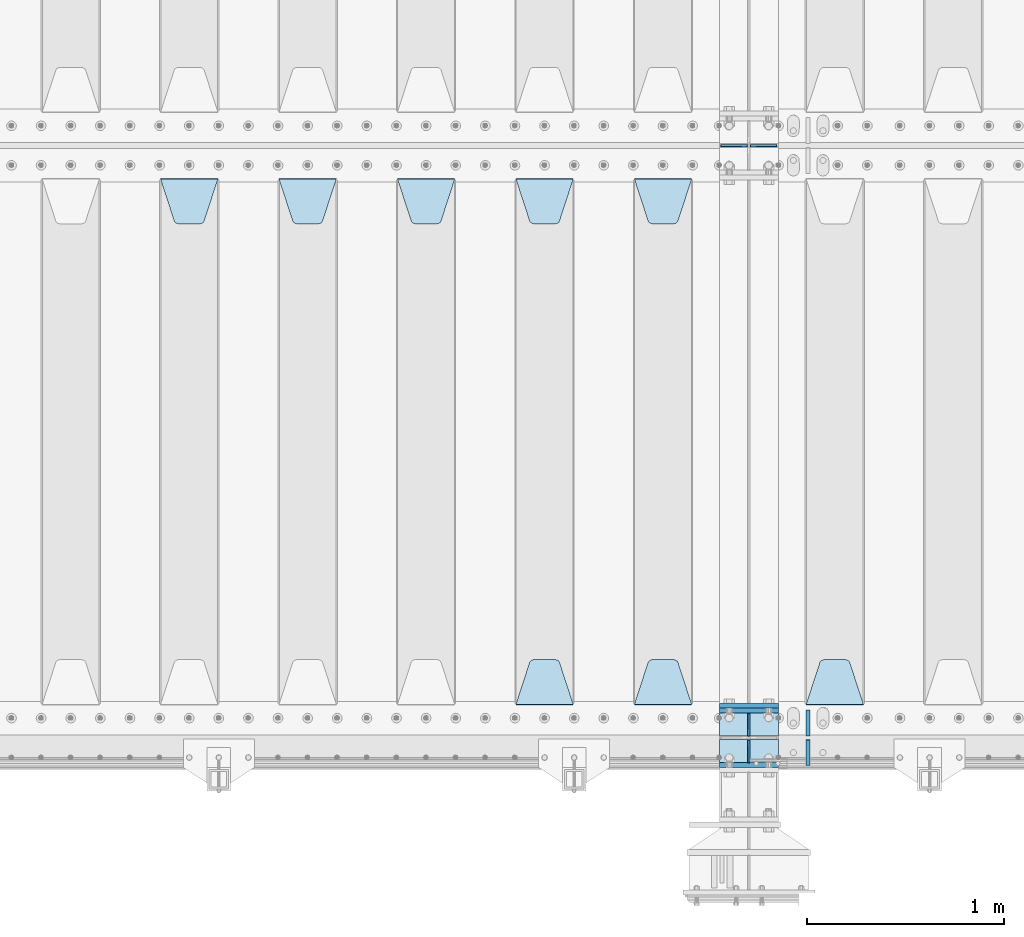
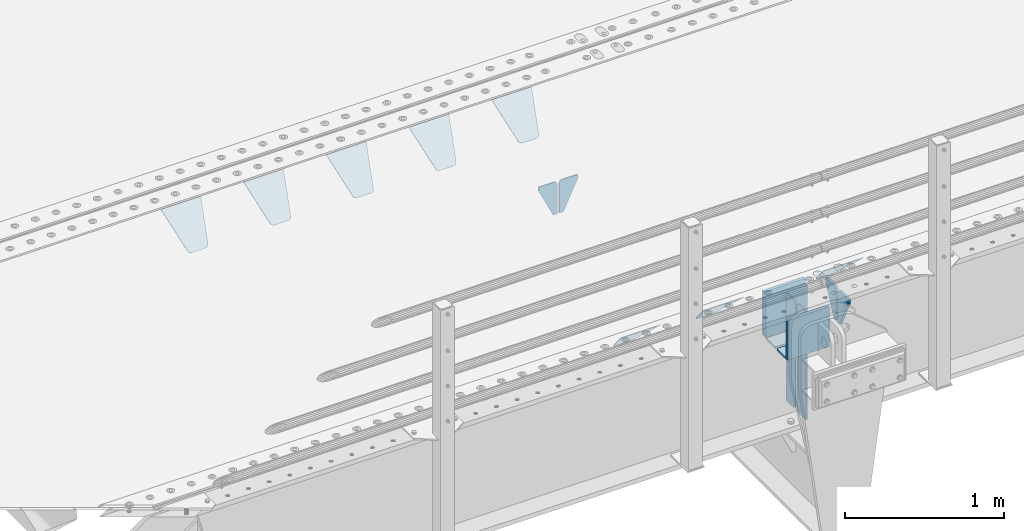
# One storey, part 224 of 270: 21 plates.
"""IFC2X3 building model written with IfcOpenShell, lengths in millimetres."""

import ifcopenshell
import ifcopenshell.guid

model = None  # the IFC model being written
_history = None  # IfcOwnerHistory: only IFC2X3 demands one
_inside = {}  # id of a spatial element -> (the spatial element, [elements in it])
_under = {}  # id of a project, library or spatial element -> (it, [spatial elements below it])
_declared = {}  # id of a project -> (the project, [libraries it declares])
_typed = {}  # id of a type object -> (the type object, [elements of that type])
_made_of = {}  # id of a material, layer set ... -> (it, [elements and type objects made of it])


def new_model(schema):
    """Start an empty IFC model of exactly this schema.

    Asked for "IFC4X3", IfcOpenShell would pick the latest addendum, in which some entities
    have other attributes; the version numbers below select the first issue.
    IFC2X3 requires an IfcOwnerHistory on every rooted entity: one is made here for all.
    """
    global model, _history
    if schema == "IFC4X3":
        model = ifcopenshell.file(schema_version=(4, 3, 0, 0))
    else:
        model = ifcopenshell.file(schema=schema)
    _inside.clear()
    _under.clear()
    _declared.clear()
    _typed.clear()
    _made_of.clear()
    _history = None
    if model.schema == "IFC2X3":
        org = make("IfcOrganization", Name="unknown")
        user = make(
            "IfcPersonAndOrganization",
            ThePerson=make("IfcPerson", FamilyName="unknown"),
            TheOrganization=org,
        )
        app = make(
            "IfcApplication",
            ApplicationDeveloper=org,
            Version="unknown",
            ApplicationFullName="unknown",
            ApplicationIdentifier="unknown",
        )
        _history = make(
            "IfcOwnerHistory",
            OwningUser=user,
            OwningApplication=app,
            ChangeAction="ADDED",
            CreationDate=0,
        )
    return model


def make(cls, **values):
    """One entity of the class cls with the attributes given. An attribute that is None is left unset."""
    return model.create_entity(
        cls, **{name: value for name, value in values.items() if value is not None}
    )


def rooted(cls, **values):
    """An entity with a GlobalId (a new one), such as an element, a storey or a relation."""
    return make(cls, GlobalId=ifcopenshell.guid.new(), OwnerHistory=_history, **values)


def si_unit(unit_type, name, prefix=None):
    """IfcSIUnit, for example si_unit("LENGTHUNIT", "METRE", prefix="MILLI")."""
    return make("IfcSIUnit", UnitType=unit_type, Prefix=prefix, Name=name)


def assignment(units):
    """IfcUnitAssignment: the units of a project."""
    return None if units is None else make("IfcUnitAssignment", Units=units)


def point(xyz):
    """IfcCartesianPoint."""
    return None if xyz is None else make("IfcCartesianPoint", Coordinates=xyz)


def direction(xyz):
    """IfcDirection."""
    return None if xyz is None else make("IfcDirection", DirectionRatios=xyz)


def frame(location, z_axis=None, x_axis=None):
    """IfcAxis2Placement3D, a coordinate frame: its origin and axes. An axis left out is left unset."""
    return make(
        "IfcAxis2Placement3D",
        Location=point(location),
        Axis=direction(z_axis),
        RefDirection=direction(x_axis),
    )


def origin_with_axes():
    """The frame at (0, 0, 0) with the z axis (0, 0, 1) and the x axis (1, 0, 0) written out."""
    return frame((0.0, 0.0, 0.0), z_axis=(0.0, 0.0, 1.0), x_axis=(1.0, 0.0, 0.0))


def place(relative_to, where):
    """IfcLocalPlacement: puts the frame where relative to a parent placement (None: the world)."""
    return make(
        "IfcLocalPlacement", PlacementRelTo=relative_to, RelativePlacement=where
    )


def context(
    kind, dimensions, precision=None, world=None, true_north=None, identifier=None
):
    """IfcGeometricRepresentationContext, for example the 3D "Model" context."""
    return make(
        "IfcGeometricRepresentationContext",
        ContextIdentifier=identifier,
        ContextType=kind,
        CoordinateSpaceDimension=dimensions,
        Precision=precision,
        WorldCoordinateSystem=world,
        TrueNorth=true_north,
    )


def subcontext(parent, identifier, kind, view, scale=None):
    """IfcGeometricRepresentationSubContext, for example "Body" below "Model"."""
    return make(
        "IfcGeometricRepresentationSubContext",
        ContextIdentifier=identifier,
        ContextType=kind,
        ParentContext=parent,
        TargetScale=scale,
        TargetView=view,
    )


def project(units=None, contexts=None):
    """IfcProject with its units and contexts."""
    return rooted(
        "IfcProject",
        Name="project",
        RepresentationContexts=contexts,
        UnitsInContext=assignment(units),
    )


def spatial(cls, under=None, at=None, **own):
    """A site, building, storey or space (cls), placed at a placement, below another one or the project."""
    s = rooted(cls, ObjectPlacement=at, **own)
    if under is not None:
        _under.setdefault(under.id(), (under, []))[1].append(s)
    return s


def faces_of(points, faces, orient=None, outer=None):
    """IfcFace entities. A face is a list of loops; a loop is a list of indices into points, from 0.

    orient and outer hold one flag for each loop. By default every Orientation is true, the
    first loop of a face is its IfcFaceOuterBound and the others are IfcFaceBound.
    """
    made = []
    for i, loops in enumerate(faces):
        bounds = []
        for j, loop in enumerate(loops):
            is_outer = j == 0 if outer is None else outer[i][j]
            bounds.append(
                make(
                    "IfcFaceOuterBound" if is_outer else "IfcFaceBound",
                    Bound=make("IfcPolyLoop", Polygon=[points[k] for k in loop]),
                    Orientation=True if orient is None else orient[i][j],
                )
            )
        made.append(make("IfcFace", Bounds=bounds))
    return made


def faceted_brep(points, faces, orient=None, outer=None, voids=None):
    """IfcFacetedBrep: a solid bounded by flat faces; with voids (closed shells), ...WithVoids."""
    shared = [point(p) for p in points]
    hull = make("IfcClosedShell", CfsFaces=faces_of(shared, faces, orient, outer))
    if voids is None:
        return make("IfcFacetedBrep", Outer=hull)
    return make(
        "IfcFacetedBrepWithVoids",
        Outer=hull,
        Voids=[
            make(cls, CfsFaces=faces_of(shared, fs, o, b)) for cls, fs, o, b in voids
        ],
    )


def shape(context_of_items, identifier, shape_type, items):
    """IfcShapeRepresentation: the items that make up one representation, for example the "Body"."""
    return make(
        "IfcShapeRepresentation",
        ContextOfItems=context_of_items,
        RepresentationIdentifier=identifier,
        RepresentationType=shape_type,
        Items=items,
    )


def material(Name=None, Category=None):
    """IfcMaterial."""
    return make("IfcMaterial", Name=Name, Category=Category)


def made_of(thing, what):
    """Note that an element or type object is made of a material, layer set ...; save() writes the relation."""
    if what is not None:
        _made_of.setdefault(what.id(), (what, []))[1].append(thing)
    return thing


def type_object(cls, material=None, **own):
    """A type object (cls), such as IfcWallType, which elements share."""
    return made_of(rooted(cls, **own), material)


def element(
    cls,
    number,
    at=None,
    inside=None,
    cuts=None,
    type_object=None,
    material=None,
    context=None,
    identifier="Body",
    shape_type=None,
    held_by="IfcProductDefinitionShape",
    body=None,
    shapes=None,
    **own,
):
    """One element of the class cls, such as IfcWall. Its Tag is "e" and its number.

    at: its placement. inside: the storey or other place that contains it. cuts: it is an
    opening in that element (IfcRelVoidsElement). A single representation is given by context,
    identifier, shape_type and body (its items); several are given by shapes. held_by: the class
    of the entity that holds the representations. save() writes the other relations.
    """
    e = rooted(cls, Tag="e%d" % number, ObjectPlacement=at, **own)
    if body is not None:
        shapes = [shape(context, identifier, shape_type, body)]
    if shapes is not None:
        e.Representation = make(held_by, Representations=shapes)
    if inside is not None:
        _inside.setdefault(inside.id(), (inside, []))[1].append(e)
    if cuts is not None:
        rooted(
            "IfcRelVoidsElement", RelatingBuildingElement=cuts, RelatedOpeningElement=e
        )
    if type_object is not None:
        _typed.setdefault(type_object.id(), (type_object, []))[1].append(e)
    return made_of(e, material)


def aggregate(whole, parts):
    """IfcRelAggregates: a whole, such as a stair, and the parts it consists of."""
    return rooted("IfcRelAggregates", RelatingObject=whole, RelatedObjects=parts)


def save(model, path):
    """Write the relations noted so far, then the file.

    IfcRelAggregates (storeys below a building ...), IfcRelContainedInSpatialStructure (elements
    in a storey), IfcRelDefinesByType, IfcRelAssociatesMaterial and IfcRelDeclares: one each for
    every whole, place, type object, material and project.
    """
    for whole, parts in _under.values():
        aggregate(whole, parts)
    for where, things in _inside.values():
        rooted(
            "IfcRelContainedInSpatialStructure",
            RelatedElements=things,
            RelatingStructure=where,
        )
    for kind, things in _typed.values():
        rooted("IfcRelDefinesByType", RelatedObjects=things, RelatingType=kind)
    for what, things in _made_of.values():
        rooted("IfcRelAssociatesMaterial", RelatedObjects=things, RelatingMaterial=what)
    for by, libraries in _declared.values():
        rooted("IfcRelDeclares", RelatingContext=by, RelatedDefinitions=libraries)
    model.write(path)


model = new_model("IFC2X3")

# Units and contexts
model_context = context("Model", 3, precision=1e-05, world=origin_with_axes())
body_context = subcontext(model_context, "Body", "Model", "MODEL_VIEW")
ifc_project = project(units=[si_unit("LENGTHUNIT", "METRE", prefix="MILLI"), si_unit("AREAUNIT", "SQUARE_METRE"), si_unit("VOLUMEUNIT", "CUBIC_METRE"), si_unit("MASSUNIT", "GRAM", prefix="KILO"), si_unit("TIMEUNIT", "SECOND"), si_unit("PLANEANGLEUNIT", "RADIAN"), si_unit("SOLIDANGLEUNIT", "STERADIAN"), si_unit("THERMODYNAMICTEMPERATUREUNIT", "DEGREE_CELSIUS"), si_unit("LUMINOUSINTENSITYUNIT", "LUMEN")], contexts=[model_context])

# Site, building, storey
site_placement = place(None, origin_with_axes())
site = spatial("IfcSite", under=ifc_project, at=site_placement, CompositionType="ELEMENT")
building_placement = place(site_placement, origin_with_axes())
building = spatial("IfcBuilding", under=site, at=building_placement, Name="Standard", CompositionType="ELEMENT")
storey_placement = place(building_placement, origin_with_axes())
storey = spatial("IfcBuildingStorey", under=building, at=storey_placement, Name="Undefined", CompositionType="ELEMENT", Elevation=0.0)

# Plates
ifc_material = material(Name="STEEL/S355N")
plate_type_1 = type_object("IfcPlateType", PredefinedType="NOTDEFINED")
plate_1_placement = place(storey_placement, frame((13885.0, -23837.5, -340.000000000044), z_axis=(0.0, 0.0, 1.0), x_axis=(1.0, 0.0, 0.0)))
element("IfcPlate", 1, at=plate_1_placement, inside=storey, type_object=plate_type_1, material=ifc_material, context=body_context, shape_type="Brep", body=[
    faceted_brep([(0.0, -12.5, 0.0), (9.27684595808387e-10, -12.5, 340.0), (9.27684595808387e-10, 12.5, 340.0), (0.0, 12.5, 0.0), (300.0, -12.5, 340.0), (300.0, 12.5, 340.0), (300.0, -12.5, 0.0), (300.0, 12.5, 0.0)], [[[0, 1, 2, 3]], [[1, 4, 5, 2]], [[4, 6, 7, 5]], [[6, 0, 3, 7]], [[5, 7, 3, 2]], [[6, 4, 1, 0]]]),
])
for number, where, z_axis, x_axis in (
    (2, (13885.0, -23862.5, -340.0), (0.0, 0.0, 1.0), (1.0, 0.0, 0.0)),
    (3, (13885.0, -24137.5, -340.0), (0.0, 0.0, 1.0), (1.0, 0.0, 0.0)),
):
    element("IfcPlate", number, at=place(storey_placement, frame(where, z_axis=z_axis, x_axis=x_axis)), inside=storey, type_object=plate_type_1, material=ifc_material, context=body_context, shape_type="Brep", body=[
        faceted_brep([(0.0, -12.5, 0.0), (0.0, -12.5, 305.0), (0.0, 12.5, 305.0), (0.0, 12.5, 0.0), (300.0, -12.5, 305.0), (300.0, 12.5, 305.0), (300.0, -12.5, 0.0), (300.0, 12.5, 0.0)], [[[0, 1, 2, 3]], [[1, 4, 5, 2]], [[4, 6, 7, 5]], [[6, 0, 3, 7]], [[5, 7, 3, 2]], [[6, 4, 1, 0]]]),
    ])
plate_type_2 = type_object("IfcPlateType", PredefinedType="NOTDEFINED")
for number, where, z_axis, x_axis in (
    (4, (13885.0, -24009.25, -343.0), (0.0, -1.0, 0.0), (1.0, 0.0, 0.0)),
    (5, (13885.0, -23990.75, -343.0), (0.0, 1.0, 0.0), (1.0, 0.0, 0.0)),
):
    element("IfcPlate", number, at=place(storey_placement, frame(where, z_axis=z_axis, x_axis=x_axis)), inside=storey, type_object=plate_type_2, material=ifc_material, context=body_context, shape_type="Brep", body=[
        faceted_brep([(0.0, -7.0, 0.0), (0.0, -7.0, 115.75), (0.0, 7.0, 115.75), (0.0, 7.0, 0.0), (300.0, -7.0, 115.75), (300.0, 7.0, 115.75), (300.0, -7.0, 0.0), (300.0, 7.0, 0.0)], [[[0, 1, 2, 3]], [[1, 4, 5, 2]], [[4, 6, 7, 5]], [[6, 0, 3, 7]], [[5, 7, 3, 2]], [[6, 4, 1, 0]]]),
    ])
plate_type_3 = type_object("IfcPlateType", PredefinedType="NOTDEFINED")
plate_2_placement = place(storey_placement, frame((14035.0, -23990.75, -35.0), z_axis=(0.0, 0.0, -1.0), x_axis=(0.0, 1.0, 0.0)))
element("IfcPlate", 6, at=plate_2_placement, inside=storey, type_object=plate_type_3, material=ifc_material, context=body_context, shape_type="Brep", body=[
    faceted_brep([(0.0, -5.0, 30.0), (0.0, -5.0, 301.0), (0.0, 5.0, 301.0), (0.0, 5.0, 30.0), (115.75, -5.0, 301.0), (115.75, 5.0, 301.0), (115.75, -5.0, 0.0), (115.75, 5.0, 0.0), (30.0, -5.0, 0.0), (30.0, 5.0, 0.0), (24.7905546699913, -5.0, 0.455767409633758), (24.7905546699913, 5.0, 0.455767409633758), (19.7393957002314, -5.0, 1.80922137642275), (19.7393957002314, 5.0, 1.80922137642275), (15.0, -5.0, 4.01923788646684), (15.0, 5.0, 4.01923788646684), (10.7163717094045, -5.0, 7.01866670643066), (10.7163717094045, 5.0, 7.01866670643066), (7.01866670642994, -5.0, 10.7163717094038), (7.01866670642994, 5.0, 10.7163717094038), (4.01923788646673, -5.0, 15.0), (4.01923788646673, 5.0, 15.0), (1.80922137642119, -5.0, 19.7393957002299), (1.80922137642119, 5.0, 19.7393957002299), (0.455767409632244, -5.0, 24.7905546699921), (0.455767409632244, 5.0, 24.7905546699921)], [[[0, 1, 2, 3]], [[1, 4, 5, 2]], [[4, 6, 7, 5]], [[6, 8, 9, 7]], [[8, 10, 11, 9]], [[10, 12, 13, 11]], [[12, 14, 15, 13]], [[14, 16, 17, 15]], [[16, 18, 19, 17]], [[18, 20, 21, 19]], [[20, 22, 23, 21]], [[22, 24, 25, 23]], [[24, 0, 3, 25]], [[5, 7, 9, 11, 13, 15, 17, 19, 21, 23, 25, 3, 2]], [[24, 22, 20, 18, 16, 14, 12, 10, 8, 6, 4, 1, 0]]]),
])
plate_3_placement = place(storey_placement, frame((14035.0, -23990.75, -350.0), z_axis=(0.0, 0.0, -1.0), x_axis=(0.0, 1.0, 0.0)))
element("IfcPlate", 7, at=plate_3_placement, inside=storey, type_object=plate_type_3, material=ifc_material, context=body_context, shape_type="Brep", body=[
    faceted_brep([(0.0, -5.0, 0.0), (0.0, -5.0, 485.0), (0.0, 5.0, 485.0), (0.0, 5.0, 0.0), (0.455767409634063, -5.0, 490.209445330008), (0.455767409634063, 5.0, 490.209445330008), (1.80922137642301, -5.0, 495.26060429977), (1.80922137642301, 5.0, 495.26060429977), (4.01923788646673, -5.0, 500.0), (4.01923788646673, 5.0, 500.0), (7.01866670642994, -5.0, 504.283628290596), (7.01866670642994, 5.0, 504.283628290596), (10.7163717094045, -5.0, 507.981333293569), (10.7163717094045, 5.0, 507.981333293569), (15.0, -5.0, 510.980762113533), (15.0, 5.0, 510.980762113533), (19.7393957002296, -5.0, 513.190778623577), (19.7393957002296, 5.0, 513.190778623577), (24.7905546699913, -5.0, 514.544232590366), (24.7905546699913, 5.0, 514.544232590366), (30.0, -5.0, 515.0), (30.0, 5.0, 515.0), (115.75, -5.0, 515.0), (115.75, 5.0, 515.0), (115.75, -5.0, 0.0), (115.75, 5.0, 0.0)], [[[0, 1, 2, 3]], [[1, 4, 5, 2]], [[4, 6, 7, 5]], [[6, 8, 9, 7]], [[8, 10, 11, 9]], [[10, 12, 13, 11]], [[12, 14, 15, 13]], [[14, 16, 17, 15]], [[16, 18, 19, 17]], [[18, 20, 21, 19]], [[20, 22, 23, 21]], [[22, 24, 25, 23]], [[24, 0, 3, 25]], [[5, 7, 9, 11, 13, 15, 17, 19, 21, 23, 25, 3, 2]], [[24, 22, 20, 18, 16, 14, 12, 10, 8, 6, 4, 1, 0]]]),
])
plate_4_placement = place(storey_placement, frame((14035.0, -24009.25, -35.0), z_axis=(0.0, 0.0, -1.0), x_axis=(0.0, -1.0, 0.0)))
element("IfcPlate", 8, at=plate_4_placement, inside=storey, type_object=plate_type_3, material=ifc_material, context=body_context, shape_type="Brep", body=[
    faceted_brep([(0.0, -5.0, 30.0), (0.0, -5.0, 301.0), (0.0, 5.0, 301.0), (0.0, 5.0, 30.0), (115.75, -5.0, 301.0), (115.75, 5.0, 301.0), (115.75, -5.0, 0.0), (115.75, 5.0, 0.0), (30.0, -5.0, 0.0), (30.0, 5.0, 0.0), (24.7905546699913, -5.0, 0.455767409633758), (24.7905546699913, 5.0, 0.455767409633758), (19.7393957002314, -5.0, 1.80922137642275), (19.7393957002314, 5.0, 1.80922137642275), (15.0, -5.0, 4.01923788646684), (15.0, 5.0, 4.01923788646684), (10.7163717094045, -5.0, 7.01866670643066), (10.7163717094045, 5.0, 7.01866670643066), (7.01866670642994, -5.0, 10.7163717094038), (7.01866670642994, 5.0, 10.7163717094038), (4.01923788646673, -5.0, 15.0), (4.01923788646673, 5.0, 15.0), (1.80922137642119, -5.0, 19.7393957002299), (1.80922137642119, 5.0, 19.7393957002299), (0.455767409632244, -5.0, 24.7905546699921), (0.455767409632244, 5.0, 24.7905546699921)], [[[0, 1, 2, 3]], [[1, 4, 5, 2]], [[4, 6, 7, 5]], [[6, 8, 9, 7]], [[8, 10, 11, 9]], [[10, 12, 13, 11]], [[12, 14, 15, 13]], [[14, 16, 17, 15]], [[16, 18, 19, 17]], [[18, 20, 21, 19]], [[20, 22, 23, 21]], [[22, 24, 25, 23]], [[24, 0, 3, 25]], [[5, 7, 9, 11, 13, 15, 17, 19, 21, 23, 25, 3, 2]], [[24, 22, 20, 18, 16, 14, 12, 10, 8, 6, 4, 1, 0]]]),
])
plate_5_placement = place(storey_placement, frame((14035.0, -24009.25, -350.0), z_axis=(0.0, 0.0, -1.0), x_axis=(0.0, -1.0, 0.0)))
element("IfcPlate", 9, at=plate_5_placement, inside=storey, type_object=plate_type_3, material=ifc_material, context=body_context, shape_type="Brep", body=[
    faceted_brep([(0.0, -5.0, 0.0), (0.0, -5.0, 485.0), (0.0, 5.0, 485.0), (0.0, 5.0, 0.0), (0.455767409634063, -5.0, 490.209445330008), (0.455767409634063, 5.0, 490.209445330008), (1.80922137642301, -5.0, 495.26060429977), (1.80922137642301, 5.0, 495.26060429977), (4.01923788646673, -5.0, 500.0), (4.01923788646673, 5.0, 500.0), (7.01866670642994, -5.0, 504.283628290596), (7.01866670642994, 5.0, 504.283628290596), (10.7163717094045, -5.0, 507.981333293569), (10.7163717094045, 5.0, 507.981333293569), (15.0, -5.0, 510.980762113533), (15.0, 5.0, 510.980762113533), (19.7393957002296, -5.0, 513.190778623577), (19.7393957002296, 5.0, 513.190778623577), (24.7905546699913, -5.0, 514.544232590366), (24.7905546699913, 5.0, 514.544232590366), (30.0, -5.0, 515.0), (30.0, 5.0, 515.0), (115.75, -5.0, 515.0), (115.75, 5.0, 515.0), (115.75, -5.0, 0.0), (115.75, 5.0, 0.0)], [[[0, 1, 2, 3]], [[1, 4, 5, 2]], [[4, 6, 7, 5]], [[6, 8, 9, 7]], [[8, 10, 11, 9]], [[10, 12, 13, 11]], [[12, 14, 15, 13]], [[14, 16, 17, 15]], [[16, 18, 19, 17]], [[18, 20, 21, 19]], [[20, 22, 23, 21]], [[22, 24, 25, 23]], [[24, 0, 3, 25]], [[5, 7, 9, 11, 13, 15, 17, 19, 21, 23, 25, 3, 2]], [[24, 22, 20, 18, 16, 14, 12, 10, 8, 6, 4, 1, 0]]]),
])
plate_type_4 = type_object("IfcPlateType", PredefinedType="NOTDEFINED")
for number, where, z_axis, x_axis in (
    (10, (14028.5000000048, -21000.0000000457, -925.000018238937), (0.0, 0.0, -1.0), (-1.0, 0.0, 0.0)),
    (11, (14041.5000000048, -21000.0000000457, -925.000018238937), (0.0, 0.0, -1.0), (1.0, 0.0, 0.0)),
):
    element("IfcPlate", number, at=place(storey_placement, frame(where, z_axis=z_axis, x_axis=x_axis)), inside=storey, type_object=plate_type_4, material=ifc_material, context=body_context, shape_type="Brep", body=[
        faceted_brep([(0.0, -5.0, 27.0), (0.0, -5.0, 250.0), (0.0, 5.0, 250.0), (0.0, 5.0, 27.0), (30.0, -5.0, 250.0), (30.0, 5.0, 250.0), (135.0, -5.0, 30.0), (135.0, 5.0, 30.0), (135.0, -5.0, 0.0), (135.0, 5.0, 0.0), (27.0, -5.0, 0.0), (27.0, 5.0, 0.0), (22.3114992029932, -5.0, 0.410190668670339), (22.3114992029932, 5.0, 0.410190668670339), (17.7654561302061, -5.0, 1.62829923878053), (17.7654561302061, 5.0, 1.62829923878053), (13.5, -5.0, 3.6173140978201), (13.5, 5.0, 3.6173140978201), (9.64473453846404, -5.0, 6.31680003578754), (9.64473453846404, 5.0, 6.31680003578754), (6.31680003578731, -5.0, 9.64473453846347), (6.31680003578731, 5.0, 9.64473453846347), (3.61731409782078, -5.0, 13.5), (3.61731409782078, 5.0, 13.5), (1.62829923878053, -5.0, 17.765456130207), (1.62829923878053, 5.0, 17.765456130207), (0.410190668670111, -5.0, 22.3114992029929), (0.410190668670111, 5.0, 22.3114992029929)], [[[0, 1, 2, 3]], [[1, 4, 5, 2]], [[4, 6, 7, 5]], [[6, 8, 9, 7]], [[8, 10, 11, 9]], [[10, 12, 13, 11]], [[12, 14, 15, 13]], [[14, 16, 17, 15]], [[16, 18, 19, 17]], [[18, 20, 21, 19]], [[20, 22, 23, 21]], [[22, 24, 25, 23]], [[24, 26, 27, 25]], [[26, 0, 3, 27]], [[5, 7, 9, 11, 13, 15, 17, 19, 21, 23, 25, 27, 3, 2]], [[26, 24, 22, 20, 18, 16, 14, 12, 10, 8, 6, 4, 1, 0]]]),
    ])
plate_type_5 = type_object("IfcPlateType", PredefinedType="NOTDEFINED")
plate_6_placement = place(storey_placement, frame((14615.0, -23831.767766953, -1.76776695296758), z_axis=(0.0, 0.707106781186547, -0.707106781186548), x_axis=(-1.0, 0.0, 0.0)))
element("IfcPlate", 12, at=plate_6_placement, inside=storey, type_object=plate_type_5, material=ifc_material, context=body_context, shape_type="Brep", body=[
    faceted_brep([(0.0, -2.5, 0.0), (69.345504679477, -2.5, 300.171731424831), (69.345504679477, 2.5, 300.171731424831), (0.0, 2.5, 0.0), (70.9274061199576, -2.5, 304.8974424154), (70.9274061199576, 2.5, 304.8974424154), (73.3818627772307, -2.49999999999818, 309.234538108527), (73.3818627772307, 2.50000000000182, 309.234538108527), (76.6187032999551, -2.5, 313.023683126103), (76.6187032999551, 2.5, 313.023683126103), (80.5190132704993, -2.5, 316.125672595372), (80.5190132704993, 2.50000000000182, 316.125672595372), (84.9395038596849, -2.49999999999818, 318.426546230476), (84.9395038596849, 2.5, 318.426546230476), (89.7177759439219, -2.49999999999818, 319.841774983275), (89.7177759439219, 2.50000000000182, 319.841774983275), (94.678286292652, -2.5, 320.319366455078), (94.678286292652, 2.5, 320.319366455078), (195.321713707348, -2.5, 320.319366455078), (195.321713707348, 2.5, 320.319366455078), (200.282224056078, -2.49999999999818, 319.841774983275), (200.282224056078, 2.50000000000182, 319.841774983275), (205.060496140315, -2.5, 318.426546230476), (205.060496140315, 2.5, 318.426546230476), (209.480986729501, -2.5, 316.12567259537), (209.480986729501, 2.50000000000182, 316.12567259537), (213.381296700045, -2.5, 313.023683126103), (213.381296700045, 2.5, 313.023683126103), (216.618137222769, -2.49999999999818, 309.234538108525), (216.618137222769, 2.50000000000182, 309.234538108527), (219.072593880042, -2.49999999999818, 304.897442415398), (219.072593880042, 2.50000000000182, 304.897442415397), (220.654495320523, -2.5, 300.171731424831), (220.654495320523, 2.5, 300.171731424831), (290.0, -2.49999999999818, 0.0), (290.0, 2.5, 0.0)], [[[0, 1, 2, 3]], [[1, 4, 5, 2]], [[4, 6, 7, 5]], [[6, 8, 9, 7]], [[8, 10, 11, 9]], [[10, 12, 13, 11]], [[12, 14, 15, 13]], [[14, 16, 17, 15]], [[16, 18, 19, 17]], [[18, 20, 21, 19]], [[20, 22, 23, 21]], [[22, 24, 25, 23]], [[24, 26, 27, 25]], [[26, 28, 29, 27]], [[28, 30, 31, 29]], [[30, 32, 33, 31]], [[32, 34, 35, 33]], [[34, 0, 3, 35]], [[5, 7, 9, 11, 13, 15, 17, 19, 21, 23, 25, 27, 29, 31, 33, 35, 3, 2]], [[34, 32, 30, 28, 26, 24, 22, 20, 18, 16, 14, 12, 10, 8, 6, 4, 1, 0]]]),
])
plate_7_placement = place(storey_placement, frame((13455.0, -21168.232233044, -1.76776695296576), z_axis=(0.0, -0.707106781186548, -0.707106781186547), x_axis=(1.0, 0.0, 0.0)))
element("IfcPlate", 13, at=plate_7_placement, inside=storey, type_object=plate_type_5, material=ifc_material, context=body_context, shape_type="Brep", body=[
    faceted_brep([(0.0, -2.5, 0.0), (69.345504679477, -2.5, 300.171731424831), (69.345504679477, 2.5, 300.171731424831), (0.0, 2.5, 0.0), (70.9274061199576, -2.5, 304.8974424154), (70.9274061199576, 2.5, 304.8974424154), (73.3818627772307, -2.49999999999818, 309.234538108527), (73.3818627772307, 2.50000000000182, 309.234538108527), (76.6187032999551, -2.5, 313.023683126103), (76.6187032999551, 2.5, 313.023683126103), (80.5190132704993, -2.5, 316.125672595372), (80.5190132704993, 2.50000000000182, 316.125672595372), (84.9395038596849, -2.49999999999818, 318.426546230476), (84.9395038596849, 2.5, 318.426546230476), (89.7177759439219, -2.49999999999818, 319.841774983275), (89.7177759439219, 2.50000000000182, 319.841774983275), (94.678286292652, -2.5, 320.319366455078), (94.678286292652, 2.5, 320.319366455078), (195.321713707348, -2.5, 320.319366455078), (195.321713707348, 2.5, 320.319366455078), (200.282224056078, -2.49999999999818, 319.841774983275), (200.282224056078, 2.50000000000182, 319.841774983275), (205.060496140315, -2.5, 318.426546230476), (205.060496140315, 2.5, 318.426546230476), (209.480986729501, -2.5, 316.12567259537), (209.480986729501, 2.50000000000182, 316.12567259537), (213.381296700045, -2.5, 313.023683126103), (213.381296700045, 2.5, 313.023683126103), (216.618137222769, -2.49999999999818, 309.234538108525), (216.618137222769, 2.50000000000182, 309.234538108527), (219.072593880042, -2.49999999999818, 304.897442415398), (219.072593880042, 2.50000000000182, 304.897442415397), (220.654495320523, -2.5, 300.171731424831), (220.654495320523, 2.5, 300.171731424831), (290.0, -2.49999999999818, 0.0), (290.0, 2.5, 0.0)], [[[0, 1, 2, 3]], [[1, 4, 5, 2]], [[4, 6, 7, 5]], [[6, 8, 9, 7]], [[8, 10, 11, 9]], [[10, 12, 13, 11]], [[12, 14, 15, 13]], [[14, 16, 17, 15]], [[16, 18, 19, 17]], [[18, 20, 21, 19]], [[20, 22, 23, 21]], [[22, 24, 25, 23]], [[24, 26, 27, 25]], [[26, 28, 29, 27]], [[28, 30, 31, 29]], [[30, 32, 33, 31]], [[32, 34, 35, 33]], [[34, 0, 3, 35]], [[5, 7, 9, 11, 13, 15, 17, 19, 21, 23, 25, 27, 29, 31, 33, 35, 3, 2]], [[34, 32, 30, 28, 26, 24, 22, 20, 18, 16, 14, 12, 10, 8, 6, 4, 1, 0]]]),
])
plate_8_placement = place(storey_placement, frame((13745.0, -23831.767766953, -1.76776695296758), z_axis=(0.0, 0.707106781186547, -0.707106781186548), x_axis=(-1.0, 0.0, 0.0)))
element("IfcPlate", 14, at=plate_8_placement, inside=storey, type_object=plate_type_5, material=ifc_material, context=body_context, shape_type="Brep", body=[
    faceted_brep([(0.0, -2.5, 0.0), (69.345504679477, -2.5, 300.171731424831), (69.345504679477, 2.5, 300.171731424831), (0.0, 2.5, 0.0), (70.9274061199576, -2.5, 304.8974424154), (70.9274061199576, 2.5, 304.8974424154), (73.3818627772307, -2.49999999999818, 309.234538108527), (73.3818627772307, 2.50000000000182, 309.234538108527), (76.6187032999551, -2.5, 313.023683126103), (76.6187032999551, 2.5, 313.023683126103), (80.5190132704993, -2.5, 316.125672595372), (80.5190132704993, 2.50000000000182, 316.125672595372), (84.9395038596849, -2.49999999999818, 318.426546230476), (84.9395038596849, 2.5, 318.426546230476), (89.7177759439219, -2.49999999999818, 319.841774983275), (89.7177759439219, 2.50000000000182, 319.841774983275), (94.678286292652, -2.5, 320.319366455078), (94.678286292652, 2.5, 320.319366455078), (195.321713707348, -2.5, 320.319366455078), (195.321713707348, 2.5, 320.319366455078), (200.282224056078, -2.49999999999818, 319.841774983275), (200.282224056078, 2.50000000000182, 319.841774983275), (205.060496140315, -2.5, 318.426546230476), (205.060496140315, 2.5, 318.426546230476), (209.480986729501, -2.5, 316.12567259537), (209.480986729501, 2.50000000000182, 316.12567259537), (213.381296700045, -2.5, 313.023683126103), (213.381296700045, 2.5, 313.023683126103), (216.618137222769, -2.49999999999818, 309.234538108525), (216.618137222769, 2.50000000000182, 309.234538108527), (219.072593880042, -2.49999999999818, 304.897442415398), (219.072593880042, 2.50000000000182, 304.897442415397), (220.654495320523, -2.5, 300.171731424831), (220.654495320523, 2.5, 300.171731424831), (290.0, -2.49999999999818, 0.0), (290.0, 2.5, 0.0)], [[[0, 1, 2, 3]], [[1, 4, 5, 2]], [[4, 6, 7, 5]], [[6, 8, 9, 7]], [[8, 10, 11, 9]], [[10, 12, 13, 11]], [[12, 14, 15, 13]], [[14, 16, 17, 15]], [[16, 18, 19, 17]], [[18, 20, 21, 19]], [[20, 22, 23, 21]], [[22, 24, 25, 23]], [[24, 26, 27, 25]], [[26, 28, 29, 27]], [[28, 30, 31, 29]], [[30, 32, 33, 31]], [[32, 34, 35, 33]], [[34, 0, 3, 35]], [[5, 7, 9, 11, 13, 15, 17, 19, 21, 23, 25, 27, 29, 31, 33, 35, 3, 2]], [[34, 32, 30, 28, 26, 24, 22, 20, 18, 16, 14, 12, 10, 8, 6, 4, 1, 0]]]),
])
plate_9_placement = place(storey_placement, frame((12855.0, -21168.232233044, -1.76776695296576), z_axis=(0.0, -0.707106781186548, -0.707106781186547), x_axis=(1.0, 0.0, 0.0)))
element("IfcPlate", 15, at=plate_9_placement, inside=storey, type_object=plate_type_5, material=ifc_material, context=body_context, shape_type="Brep", body=[
    faceted_brep([(0.0, -2.5, 0.0), (69.345504679477, -2.5, 300.171731424831), (69.345504679477, 2.5, 300.171731424831), (0.0, 2.5, 0.0), (70.9274061199576, -2.5, 304.8974424154), (70.9274061199576, 2.5, 304.8974424154), (73.3818627772307, -2.49999999999818, 309.234538108527), (73.3818627772307, 2.50000000000182, 309.234538108527), (76.6187032999551, -2.5, 313.023683126103), (76.6187032999551, 2.5, 313.023683126103), (80.5190132704993, -2.5, 316.125672595372), (80.5190132704993, 2.50000000000182, 316.125672595372), (84.9395038596849, -2.49999999999818, 318.426546230476), (84.9395038596849, 2.5, 318.426546230476), (89.7177759439219, -2.49999999999818, 319.841774983275), (89.7177759439219, 2.50000000000182, 319.841774983275), (94.678286292652, -2.5, 320.319366455078), (94.678286292652, 2.5, 320.319366455078), (195.321713707348, -2.5, 320.319366455078), (195.321713707348, 2.5, 320.319366455078), (200.282224056078, -2.49999999999818, 319.841774983275), (200.282224056078, 2.50000000000182, 319.841774983275), (205.060496140315, -2.5, 318.426546230476), (205.060496140315, 2.5, 318.426546230476), (209.480986729501, -2.5, 316.12567259537), (209.480986729501, 2.50000000000182, 316.12567259537), (213.381296700045, -2.5, 313.023683126103), (213.381296700045, 2.5, 313.023683126103), (216.618137222769, -2.49999999999818, 309.234538108525), (216.618137222769, 2.50000000000182, 309.234538108527), (219.072593880042, -2.49999999999818, 304.897442415398), (219.072593880042, 2.50000000000182, 304.897442415397), (220.654495320523, -2.5, 300.171731424831), (220.654495320523, 2.5, 300.171731424831), (290.0, -2.49999999999818, 0.0), (290.0, 2.5, 0.0)], [[[0, 1, 2, 3]], [[1, 4, 5, 2]], [[4, 6, 7, 5]], [[6, 8, 9, 7]], [[8, 10, 11, 9]], [[10, 12, 13, 11]], [[12, 14, 15, 13]], [[14, 16, 17, 15]], [[16, 18, 19, 17]], [[18, 20, 21, 19]], [[20, 22, 23, 21]], [[22, 24, 25, 23]], [[24, 26, 27, 25]], [[26, 28, 29, 27]], [[28, 30, 31, 29]], [[30, 32, 33, 31]], [[32, 34, 35, 33]], [[34, 0, 3, 35]], [[5, 7, 9, 11, 13, 15, 17, 19, 21, 23, 25, 27, 29, 31, 33, 35, 3, 2]], [[34, 32, 30, 28, 26, 24, 22, 20, 18, 16, 14, 12, 10, 8, 6, 4, 1, 0]]]),
])
plate_10_placement = place(storey_placement, frame((13145.0, -23831.767766953, -1.76776695296758), z_axis=(0.0, 0.707106781186547, -0.707106781186548), x_axis=(-1.0, 0.0, 0.0)))
element("IfcPlate", 16, at=plate_10_placement, inside=storey, type_object=plate_type_5, material=ifc_material, context=body_context, shape_type="Brep", body=[
    faceted_brep([(0.0, -2.5, 0.0), (69.345504679477, -2.5, 300.171731424831), (69.345504679477, 2.5, 300.171731424831), (0.0, 2.5, 0.0), (70.9274061199576, -2.5, 304.8974424154), (70.9274061199576, 2.5, 304.8974424154), (73.3818627772307, -2.49999999999818, 309.234538108527), (73.3818627772307, 2.50000000000182, 309.234538108527), (76.6187032999551, -2.5, 313.023683126103), (76.6187032999551, 2.5, 313.023683126103), (80.5190132704993, -2.5, 316.125672595372), (80.5190132704993, 2.50000000000182, 316.125672595372), (84.9395038596849, -2.49999999999818, 318.426546230476), (84.9395038596849, 2.5, 318.426546230476), (89.7177759439219, -2.49999999999818, 319.841774983275), (89.7177759439219, 2.50000000000182, 319.841774983275), (94.678286292652, -2.5, 320.319366455078), (94.678286292652, 2.5, 320.319366455078), (195.321713707348, -2.5, 320.319366455078), (195.321713707348, 2.5, 320.319366455078), (200.282224056078, -2.49999999999818, 319.841774983275), (200.282224056078, 2.50000000000182, 319.841774983275), (205.060496140315, -2.5, 318.426546230476), (205.060496140315, 2.5, 318.426546230476), (209.480986729501, -2.5, 316.12567259537), (209.480986729501, 2.50000000000182, 316.12567259537), (213.381296700045, -2.5, 313.023683126103), (213.381296700045, 2.5, 313.023683126103), (216.618137222769, -2.49999999999818, 309.234538108525), (216.618137222769, 2.50000000000182, 309.234538108527), (219.072593880042, -2.49999999999818, 304.897442415398), (219.072593880042, 2.50000000000182, 304.897442415397), (220.654495320523, -2.5, 300.171731424831), (220.654495320523, 2.5, 300.171731424831), (290.0, -2.49999999999818, 0.0), (290.0, 2.5, 0.0)], [[[0, 1, 2, 3]], [[1, 4, 5, 2]], [[4, 6, 7, 5]], [[6, 8, 9, 7]], [[8, 10, 11, 9]], [[10, 12, 13, 11]], [[12, 14, 15, 13]], [[14, 16, 17, 15]], [[16, 18, 19, 17]], [[18, 20, 21, 19]], [[20, 22, 23, 21]], [[22, 24, 25, 23]], [[24, 26, 27, 25]], [[26, 28, 29, 27]], [[28, 30, 31, 29]], [[30, 32, 33, 31]], [[32, 34, 35, 33]], [[34, 0, 3, 35]], [[5, 7, 9, 11, 13, 15, 17, 19, 21, 23, 25, 27, 29, 31, 33, 35, 3, 2]], [[34, 32, 30, 28, 26, 24, 22, 20, 18, 16, 14, 12, 10, 8, 6, 4, 1, 0]]]),
])
plate_11_placement = place(storey_placement, frame((12255.0, -21168.232233044, -1.76776695296576), z_axis=(0.0, -0.707106781186548, -0.707106781186547), x_axis=(1.0, 0.0, 0.0)))
element("IfcPlate", 17, at=plate_11_placement, inside=storey, type_object=plate_type_5, material=ifc_material, context=body_context, shape_type="Brep", body=[
    faceted_brep([(0.0, -2.5, 0.0), (69.345504679477, -2.5, 300.171731424831), (69.345504679477, 2.5, 300.171731424831), (0.0, 2.5, 0.0), (70.9274061199576, -2.5, 304.8974424154), (70.9274061199576, 2.5, 304.8974424154), (73.3818627772307, -2.49999999999818, 309.234538108527), (73.3818627772307, 2.50000000000182, 309.234538108527), (76.6187032999551, -2.5, 313.023683126103), (76.6187032999551, 2.5, 313.023683126103), (80.5190132704993, -2.5, 316.125672595372), (80.5190132704993, 2.50000000000182, 316.125672595372), (84.9395038596849, -2.49999999999818, 318.426546230476), (84.9395038596849, 2.5, 318.426546230476), (89.7177759439219, -2.49999999999818, 319.841774983275), (89.7177759439219, 2.50000000000182, 319.841774983275), (94.678286292652, -2.5, 320.319366455078), (94.678286292652, 2.5, 320.319366455078), (195.321713707348, -2.5, 320.319366455078), (195.321713707348, 2.5, 320.319366455078), (200.282224056078, -2.49999999999818, 319.841774983275), (200.282224056078, 2.50000000000182, 319.841774983275), (205.060496140315, -2.5, 318.426546230476), (205.060496140315, 2.5, 318.426546230476), (209.480986729501, -2.5, 316.12567259537), (209.480986729501, 2.50000000000182, 316.12567259537), (213.381296700045, -2.5, 313.023683126103), (213.381296700045, 2.5, 313.023683126103), (216.618137222769, -2.49999999999818, 309.234538108525), (216.618137222769, 2.50000000000182, 309.234538108527), (219.072593880042, -2.49999999999818, 304.897442415398), (219.072593880042, 2.50000000000182, 304.897442415397), (220.654495320523, -2.5, 300.171731424831), (220.654495320523, 2.5, 300.171731424831), (290.0, -2.49999999999818, 0.0), (290.0, 2.5, 0.0)], [[[0, 1, 2, 3]], [[1, 4, 5, 2]], [[4, 6, 7, 5]], [[6, 8, 9, 7]], [[8, 10, 11, 9]], [[10, 12, 13, 11]], [[12, 14, 15, 13]], [[14, 16, 17, 15]], [[16, 18, 19, 17]], [[18, 20, 21, 19]], [[20, 22, 23, 21]], [[22, 24, 25, 23]], [[24, 26, 27, 25]], [[26, 28, 29, 27]], [[28, 30, 31, 29]], [[30, 32, 33, 31]], [[32, 34, 35, 33]], [[34, 0, 3, 35]], [[5, 7, 9, 11, 13, 15, 17, 19, 21, 23, 25, 27, 29, 31, 33, 35, 3, 2]], [[34, 32, 30, 28, 26, 24, 22, 20, 18, 16, 14, 12, 10, 8, 6, 4, 1, 0]]]),
])
plate_12_placement = place(storey_placement, frame((11655.0, -21168.232233044, -1.76776695296576), z_axis=(0.0, -0.707106781186548, -0.707106781186547), x_axis=(1.0, 0.0, 0.0)))
element("IfcPlate", 18, at=plate_12_placement, inside=storey, type_object=plate_type_5, material=ifc_material, context=body_context, shape_type="Brep", body=[
    faceted_brep([(0.0, -2.5, 0.0), (69.345504679477, -2.5, 300.171731424831), (69.345504679477, 2.5, 300.171731424831), (0.0, 2.5, 0.0), (70.9274061199576, -2.5, 304.8974424154), (70.9274061199576, 2.5, 304.8974424154), (73.3818627772307, -2.49999999999818, 309.234538108527), (73.3818627772307, 2.50000000000182, 309.234538108527), (76.6187032999551, -2.5, 313.023683126103), (76.6187032999551, 2.5, 313.023683126103), (80.5190132704993, -2.5, 316.125672595372), (80.5190132704993, 2.50000000000182, 316.125672595372), (84.9395038596849, -2.49999999999818, 318.426546230476), (84.9395038596849, 2.5, 318.426546230476), (89.7177759439219, -2.49999999999818, 319.841774983275), (89.7177759439219, 2.50000000000182, 319.841774983275), (94.678286292652, -2.5, 320.319366455078), (94.678286292652, 2.5, 320.319366455078), (195.321713707348, -2.5, 320.319366455078), (195.321713707348, 2.5, 320.319366455078), (200.282224056078, -2.49999999999818, 319.841774983275), (200.282224056078, 2.50000000000182, 319.841774983275), (205.060496140315, -2.5, 318.426546230476), (205.060496140315, 2.5, 318.426546230476), (209.480986729501, -2.5, 316.12567259537), (209.480986729501, 2.50000000000182, 316.12567259537), (213.381296700045, -2.5, 313.023683126103), (213.381296700045, 2.5, 313.023683126103), (216.618137222769, -2.49999999999818, 309.234538108525), (216.618137222769, 2.50000000000182, 309.234538108527), (219.072593880042, -2.49999999999818, 304.897442415398), (219.072593880042, 2.50000000000182, 304.897442415397), (220.654495320523, -2.5, 300.171731424831), (220.654495320523, 2.5, 300.171731424831), (290.0, -2.49999999999818, 0.0), (290.0, 2.5, 0.0)], [[[0, 1, 2, 3]], [[1, 4, 5, 2]], [[4, 6, 7, 5]], [[6, 8, 9, 7]], [[8, 10, 11, 9]], [[10, 12, 13, 11]], [[12, 14, 15, 13]], [[14, 16, 17, 15]], [[16, 18, 19, 17]], [[18, 20, 21, 19]], [[20, 22, 23, 21]], [[22, 24, 25, 23]], [[24, 26, 27, 25]], [[26, 28, 29, 27]], [[28, 30, 31, 29]], [[30, 32, 33, 31]], [[32, 34, 35, 33]], [[34, 0, 3, 35]], [[5, 7, 9, 11, 13, 15, 17, 19, 21, 23, 25, 27, 29, 31, 33, 35, 3, 2]], [[34, 32, 30, 28, 26, 24, 22, 20, 18, 16, 14, 12, 10, 8, 6, 4, 1, 0]]]),
])
plate_13_placement = place(storey_placement, frame((11055.0, -21168.232233044, -1.76776695296576), z_axis=(0.0, -0.707106781186548, -0.707106781186547), x_axis=(1.0, 0.0, 0.0)))
element("IfcPlate", 19, at=plate_13_placement, inside=storey, type_object=plate_type_5, material=ifc_material, context=body_context, shape_type="Brep", body=[
    faceted_brep([(0.0, -2.5, 0.0), (69.345504679477, -2.5, 300.171731424831), (69.345504679477, 2.5, 300.171731424831), (0.0, 2.5, 0.0), (70.9274061199576, -2.5, 304.8974424154), (70.9274061199576, 2.5, 304.8974424154), (73.3818627772307, -2.49999999999818, 309.234538108527), (73.3818627772307, 2.50000000000182, 309.234538108527), (76.6187032999551, -2.5, 313.023683126103), (76.6187032999551, 2.5, 313.023683126103), (80.5190132704993, -2.5, 316.125672595372), (80.5190132704993, 2.50000000000182, 316.125672595372), (84.9395038596849, -2.49999999999818, 318.426546230476), (84.9395038596849, 2.5, 318.426546230476), (89.7177759439219, -2.49999999999818, 319.841774983275), (89.7177759439219, 2.50000000000182, 319.841774983275), (94.678286292652, -2.5, 320.319366455078), (94.678286292652, 2.5, 320.319366455078), (195.321713707348, -2.5, 320.319366455078), (195.321713707348, 2.5, 320.319366455078), (200.282224056078, -2.49999999999818, 319.841774983275), (200.282224056078, 2.50000000000182, 319.841774983275), (205.060496140315, -2.5, 318.426546230476), (205.060496140315, 2.5, 318.426546230476), (209.480986729501, -2.5, 316.12567259537), (209.480986729501, 2.50000000000182, 316.12567259537), (213.381296700045, -2.5, 313.023683126103), (213.381296700045, 2.5, 313.023683126103), (216.618137222769, -2.49999999999818, 309.234538108525), (216.618137222769, 2.50000000000182, 309.234538108527), (219.072593880042, -2.49999999999818, 304.897442415398), (219.072593880042, 2.50000000000182, 304.897442415397), (220.654495320523, -2.5, 300.171731424831), (220.654495320523, 2.5, 300.171731424831), (290.0, -2.49999999999818, 0.0), (290.0, 2.5, 0.0)], [[[0, 1, 2, 3]], [[1, 4, 5, 2]], [[4, 6, 7, 5]], [[6, 8, 9, 7]], [[8, 10, 11, 9]], [[10, 12, 13, 11]], [[12, 14, 15, 13]], [[14, 16, 17, 15]], [[16, 18, 19, 17]], [[18, 20, 21, 19]], [[20, 22, 23, 21]], [[22, 24, 25, 23]], [[24, 26, 27, 25]], [[26, 28, 29, 27]], [[28, 30, 31, 29]], [[30, 32, 33, 31]], [[32, 34, 35, 33]], [[34, 0, 3, 35]], [[5, 7, 9, 11, 13, 15, 17, 19, 21, 23, 25, 27, 29, 31, 33, 35, 3, 2]], [[34, 32, 30, 28, 26, 24, 22, 20, 18, 16, 14, 12, 10, 8, 6, 4, 1, 0]]]),
])
plate_type_6 = type_object("IfcPlateType", PredefinedType="NOTDEFINED")
for number, where, z_axis, x_axis in (
    (20, (14335.0, -23858.75, -35.0), (0.0, 0.0, -1.0), (0.0, -1.0, 0.0)),
    (21, (14335.0, -24141.25, -35.0), (0.0, 0.0, -1.0), (0.0, 1.0, 0.0)),
):
    element("IfcPlate", number, at=place(storey_placement, frame(where, z_axis=z_axis, x_axis=x_axis)), inside=storey, type_object=plate_type_6, material=ifc_material, context=body_context, shape_type="Brep", body=[
        faceted_brep([(0.0, -10.0, 0.0), (0.0, -10.0, 30.0), (0.0, 10.0, 30.0), (0.0, 10.0, 0.0), (102.0, -10.0, 250.0), (102.0, 10.0, 250.0), (132.0, -10.0, 250.0), (132.0, 10.0, 250.0), (132.0, -10.0, 30.0), (132.0, 10.0, 30.0), (131.544232590368, -10.0, 24.790554669992), (131.544232590368, 10.0, 24.790554669992), (130.190778623579, -10.0, 19.7393957002299), (130.190778623579, 10.0, 19.7393957002299), (127.980762113533, -10.0, 15.0), (127.980762113533, 10.0, 15.0), (124.98133329357, -10.0, 10.7163717094038), (124.98133329357, 10.0, 10.7163717094038), (121.283628290596, -10.0, 7.01866670643062), (121.283628290596, 10.0, 7.01866670643062), (117.0, -10.0, 4.01923788646684), (117.0, 10.0, 4.01923788646684), (112.260604299769, -10.0, 1.80922137642278), (112.260604299769, 10.0, 1.80922137642278), (107.209445330009, -10.0, 0.455767409633722), (107.209445330009, 10.0, 0.455767409633722), (102.0, -10.0, 0.0), (102.0, 10.0, 0.0)], [[[0, 1, 2, 3]], [[1, 4, 5, 2]], [[4, 6, 7, 5]], [[6, 8, 9, 7]], [[8, 10, 11, 9]], [[10, 12, 13, 11]], [[12, 14, 15, 13]], [[14, 16, 17, 15]], [[16, 18, 19, 17]], [[18, 20, 21, 19]], [[20, 22, 23, 21]], [[22, 24, 25, 23]], [[24, 26, 27, 25]], [[26, 0, 3, 27]], [[5, 7, 9, 11, 13, 15, 17, 19, 21, 23, 25, 27, 3, 2]], [[26, 24, 22, 20, 18, 16, 14, 12, 10, 8, 6, 4, 1, 0]]]),
    ])

save(model, "model.ifc")
